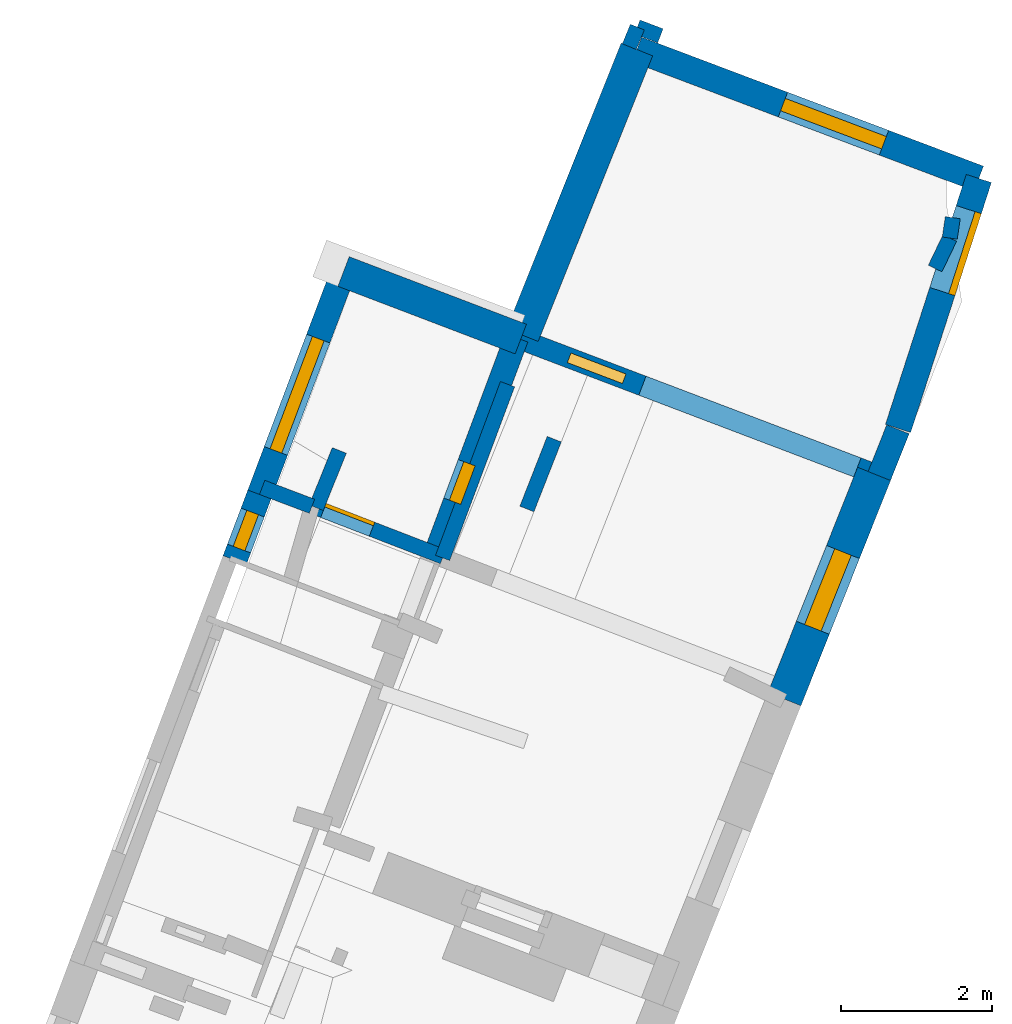
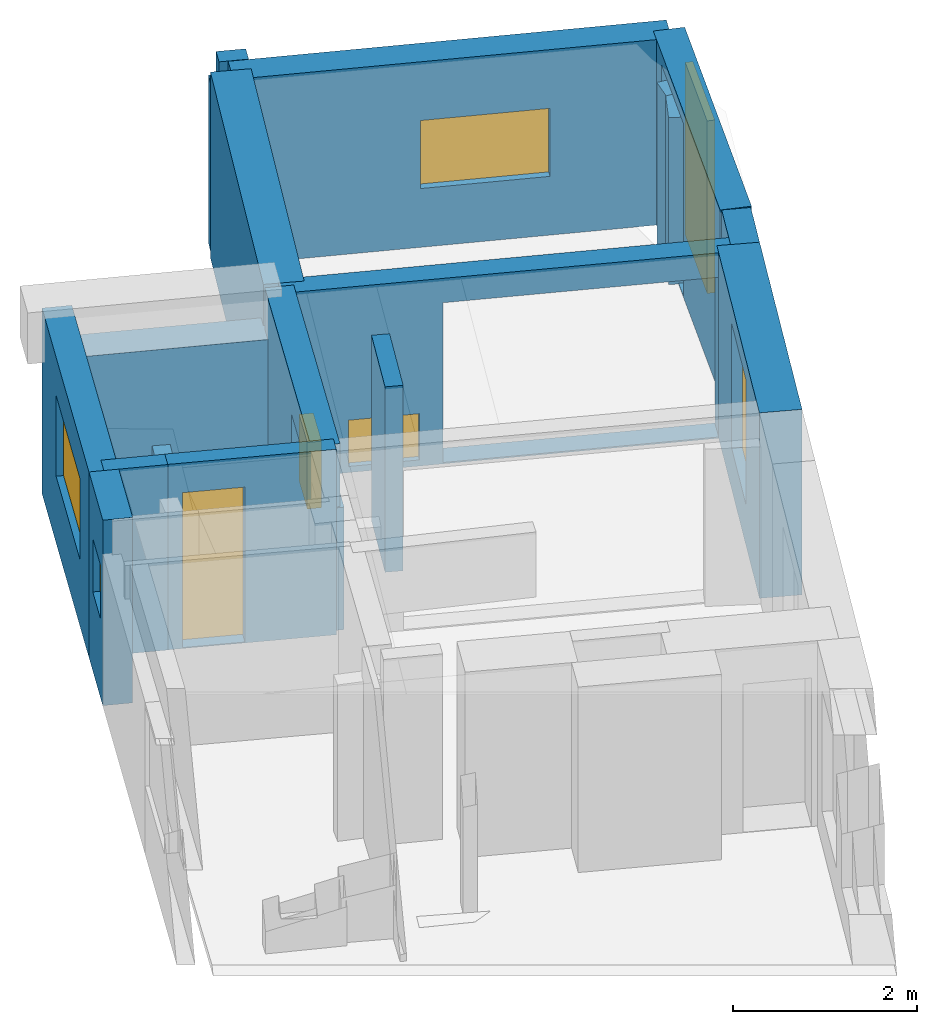
# One storey, part 3 of 5: 19 walls, 6 windows, 2 doors, 9 openings.
"""IFC2X3 building model written with IfcOpenShell, lengths in metres."""

from ifc_helpers import new_model, entity, si_unit, converted_unit, derived_unit, direction, frame, frame_2d, origin, origin_2d_with_axis, place, context, subcontext, project, spatial, polyline, rectangle, outline, extrude, source, transform, mapped, material, layer, layer_set, layer_usage, type_object, type_shapes, element, fill, save


model = new_model("IFC2X3")

# Units and contexts
model_context = context("Model", 3, precision=1e-05, world=origin(), true_north=direction((0.0, 1.0)))
body_context = subcontext(model_context, "Body", "Model", "MODEL_VIEW")
ifc_project = project(units=[si_unit("LENGTHUNIT", "METRE"), si_unit("AREAUNIT", "SQUARE_METRE"), si_unit("VOLUMEUNIT", "CUBIC_METRE"), converted_unit("PLANEANGLEUNIT", "DEGREE", entity("IfcRatioMeasure", 0.0174532925199433), si_unit("PLANEANGLEUNIT", "RADIAN"), dimensions=[0, 0, 0, 0, 0, 0, 0]), si_unit("MASSUNIT", "GRAM", prefix="KILO"), derived_unit("MASSDENSITYUNIT", [(si_unit("MASSUNIT", "GRAM", prefix="KILO"), 1), (si_unit("LENGTHUNIT", "METRE"), -3)]), derived_unit("MOMENTOFINERTIAUNIT", [(si_unit("LENGTHUNIT", "METRE"), 4)]), si_unit("TIMEUNIT", "SECOND"), si_unit("FREQUENCYUNIT", "HERTZ"), si_unit("THERMODYNAMICTEMPERATUREUNIT", "DEGREE_CELSIUS"), derived_unit("THERMALTRANSMITTANCEUNIT", [(si_unit("MASSUNIT", "GRAM", prefix="KILO"), 1), (si_unit("THERMODYNAMICTEMPERATUREUNIT", "KELVIN"), -1), (si_unit("TIMEUNIT", "SECOND"), -3)]), derived_unit("VOLUMETRICFLOWRATEUNIT", [(si_unit("LENGTHUNIT", "METRE"), 3), (si_unit("TIMEUNIT", "SECOND"), -1)]), si_unit("ELECTRICCURRENTUNIT", "AMPERE"), si_unit("ELECTRICVOLTAGEUNIT", "VOLT"), si_unit("POWERUNIT", "WATT"), si_unit("FORCEUNIT", "NEWTON", prefix="KILO"), si_unit("ILLUMINANCEUNIT", "LUX"), si_unit("LUMINOUSFLUXUNIT", "LUMEN"), si_unit("LUMINOUSINTENSITYUNIT", "CANDELA"), derived_unit("USERDEFINED", [(si_unit("MASSUNIT", "GRAM", prefix="KILO"), -1), (si_unit("LENGTHUNIT", "METRE"), -2), (si_unit("TIMEUNIT", "SECOND"), 3), (si_unit("LUMINOUSFLUXUNIT", "LUMEN"), 1)]), derived_unit("LINEARVELOCITYUNIT", [(si_unit("LENGTHUNIT", "METRE"), 1), (si_unit("TIMEUNIT", "SECOND"), -1)]), si_unit("PRESSUREUNIT", "PASCAL"), derived_unit("USERDEFINED", [(si_unit("LENGTHUNIT", "METRE"), -2), (si_unit("MASSUNIT", "GRAM", prefix="KILO"), 1), (si_unit("TIMEUNIT", "SECOND"), -2)]), derived_unit("LINEARFORCEUNIT", [(si_unit("MASSUNIT", "GRAM", prefix="KILO"), 1), (si_unit("LENGTHUNIT", "METRE"), 1), (si_unit("TIMEUNIT", "SECOND"), -2), (si_unit("LENGTHUNIT", "METRE"), -1)]), derived_unit("PLANARFORCEUNIT", [(si_unit("MASSUNIT", "GRAM", prefix="KILO"), 1), (si_unit("LENGTHUNIT", "METRE"), 1), (si_unit("TIMEUNIT", "SECOND"), -2), (si_unit("LENGTHUNIT", "METRE"), -2)])], contexts=[model_context])

# Site, building, storey
placement_1 = place(None, origin())
site = spatial("IfcSite", under=ifc_project, at=placement_1, CompositionType="ELEMENT")
building = spatial("IfcBuilding", under=site, at=placement_1, CompositionType="ELEMENT")
storey_placement = place(placement_1, frame((0.0, 0.0, -81.7791442871094)))
storey = spatial("IfcBuildingStorey", under=building, at=storey_placement, Name="Level 1", CompositionType="ELEMENT", Elevation=-81.7791442871094)

# Walls
ifc_material_1 = material(Name="Default wall")
ifc_layer_1 = layer(ifc_material_1, 0.2)
ifc_layer_set_1 = layer_set([ifc_layer_1], Name="wall_thickness_0.2000")
ifc_layer_usage_1 = layer_usage(ifc_layer_set_1, "AXIS2", "POSITIVE", -0.1)
wall_type_1 = type_object("IfcWallType", Name="wall_thickness_0.2000", PredefinedType="STANDARD", material=ifc_layer_set_1)
wall_1_placement = place(storey_placement, frame((0.534913213173563, 14.0127489770856, 0.0), z_axis=(0.0, 0.0, 1.0), x_axis=(-0.379483090969184, -0.925198672539295, 0.0)))
element("IfcWallStandardCase", 1, at=wall_1_placement, inside=storey, type_object=wall_type_1, material=ifc_layer_usage_1, Name="Wall:28", ObjectType="Wall", context=body_context, shape_type="SweptSolid", body=[
    extrude(outline(polyline([(0.280202532892846, -0.1), (0.280202532892846, 0.1), (0.0, 0.1), (0.0, -0.1), (0.280202532892846, -0.1)])), origin(), (0.0, 0.0, 1.0), 2.23354339599609),
])
wall_2_placement = place(storey_placement, frame((-1.18385248926495, 9.2848220301749, 0.0), z_axis=(0.0, 0.0, 1.0), x_axis=(-0.350013235977409, -0.936744754263734, 0.0)))
element("IfcWallStandardCase", 2, at=wall_2_placement, inside=storey, type_object=wall_type_1, material=ifc_layer_usage_1, Name="Wall:30", ObjectType="Wall", context=body_context, shape_type="SweptSolid", body=[
    extrude(outline(polyline([(2.45518731970475, -0.1), (2.45518731970475, 0.1), (0.0, 0.1), (0.0, -0.1), (2.45518731970475, -0.1)])), origin(), (0.0, 0.0, 1.0), 1.62880706787109),
])
wall_3_placement = place(storey_placement, frame((-0.565016196030518, 8.55692528998831, 0.0), z_axis=(0.0, 0.0, 1.0), x_axis=(-0.365185671787063, -0.930934705079487, 0.0)))
element("IfcWallStandardCase", 3, at=wall_3_placement, inside=storey, type_object=wall_type_1, material=ifc_layer_usage_1, Name="Wall:49", ObjectType="Wall", context=body_context, shape_type="SweptSolid", body=[
    extrude(outline(polyline([(0.992160278720663, -0.1), (0.992160278720663, 0.1), (0.0, 0.1), (0.0, -0.1), (0.992160278720663, -0.1)])), origin(), (0.0, 0.0, 1.0), 2.46645965576172),
])
wall_4_placement = place(storey_placement, frame((-3.41037913404314, 8.40823391612898, 0.0), z_axis=(0.0, 0.0, 1.0), x_axis=(-0.373585462771067, -0.927595764331709, 0.0)))
element("IfcWallStandardCase", 4, at=wall_4_placement, inside=storey, type_object=wall_type_1, material=ifc_layer_usage_1, Name="Wall:53", ObjectType="Wall", context=body_context, shape_type="SweptSolid", body=[
    extrude(outline(polyline([(0.817462287306369, -0.1), (0.817462287306369, 0.1), (0.0, 0.1), (0.0, -0.1), (0.817462287306369, -0.1)])), origin(), (0.0, 0.0, 1.0), 2.08080291748047),
])
wall_5_placement = place(storey_placement, frame((0.840400958394622, 13.8964334556276, 0.0), z_axis=(0.0, 0.0, 1.0), x_axis=(-0.934550229836624, 0.355831235155535, 0.0)))
element("IfcWallStandardCase", 5, at=wall_5_placement, inside=storey, type_object=wall_type_1, material=ifc_layer_usage_1, Name="Wall:54", ObjectType="Wall", context=body_context, shape_type="SweptSolid", body=[
    extrude(outline(polyline([(0.326882174774922, -0.1), (0.326882174774922, 0.1), (0.0, 0.1), (0.0, -0.1), (0.326882174774922, -0.1)])), origin(), (0.0, 0.0, 1.0), 2.46645965576172),
])
wall_6_placement = place(storey_placement, frame((4.67075637080237, 11.2193282866582, 0.0), z_axis=(0.0, 0.0, 1.0), x_axis=(-0.432838851442395, -0.901471313288464, 0.0)))
element("IfcWallStandardCase", 6, at=wall_6_placement, inside=storey, type_object=wall_type_1, material=ifc_layer_usage_1, Name="Wall:77", ObjectType="Wall", context=body_context, shape_type="SweptSolid", body=[
    extrude(outline(polyline([(0.447134619766838, -0.1), (0.447134619766838, 0.1), (0.0, 0.1), (0.0, -0.1), (0.447134619766838, -0.1)])), origin(), (0.0, 0.0, 1.0), 2.21805572509766),
])
wall_7_placement = place(storey_placement, frame((-4.43193251056362, 7.91902260949432, 0.0), z_axis=(0.0, 0.0, 1.0), x_axis=(0.93509236593609, -0.354404101511319, 0.0)))
element("IfcWallStandardCase", 7, at=wall_7_placement, inside=storey, type_object=wall_type_1, material=ifc_layer_usage_1, Name="Wall:83", ObjectType="Wall", context=body_context, shape_type="SweptSolid", body=[
    extrude(outline(polyline([(0.705679881249374, -0.1), (0.705679881249374, 0.1), (0.0, 0.1), (0.0, -0.1), (0.705679881249374, -0.1)])), origin(), (0.0, 0.0, 1.0), 2.46645965576172),
])
wall_8_placement = place(storey_placement, frame((4.71052920471825, 11.4896001543903, 0.0), z_axis=(0.0, 0.0, 1.0), x_axis=(-0.145589265881267, -0.98934511959182, 0.0)))
element("IfcWallStandardCase", 8, at=wall_8_placement, inside=storey, type_object=wall_type_1, material=ifc_layer_usage_1, Name="Wall:87", ObjectType="Wall", context=body_context, shape_type="SweptSolid", body=[
    extrude(outline(polyline([(0.273182986999881, -0.1), (0.273182986999881, 0.1), (0.0, 0.1), (0.0, -0.1), (0.273182986999881, -0.1)])), origin(), (0.0, 0.0, 1.0), 2.21805572509766),
])

# Wall, opening, window
ifc_layer_2 = layer(ifc_material_1, 0.330000013113022)
ifc_layer_set_2 = layer_set([ifc_layer_2], Name="wall_thickness_0.3300")
ifc_layer_usage_2 = layer_usage(ifc_layer_set_2, "AXIS2", "POSITIVE", -0.165000006556511)
wall_type_2 = type_object("IfcWallType", Name="wall_thickness_0.3300", PredefinedType="STANDARD", material=ifc_layer_set_2)
wall_9_placement = place(storey_placement, frame((-3.35402105928155, 10.7769497737443, 0.0), z_axis=(0.0, 0.0, 1.0), x_axis=(-0.352899233573497, -0.935661333465928, 0.0)))
wall_9 = element("IfcWallStandardCase", 9, at=wall_9_placement, inside=storey, type_object=wall_type_2, material=ifc_layer_usage_2, Name="Wall:5", ObjectType="Wall", context=body_context, shape_type="SweptSolid", body=[
    extrude(outline(polyline([(3.15444612027682, -0.165000006556511), (3.15444612027682, 0.165000006556511), (0.0, 0.165000006556511), (0.0, -0.165000006556511), (3.15444612027682, -0.165000006556511)])), origin(), (0.0, 0.0, 1.0), 2.46645965576172),
])
opening_1_placement = place(wall_9_placement, frame((0.94920766898592, -0.165000006556511, 0.885063171386719)))
opening_1 = element("IfcOpeningElement", 10, at=opening_1_placement, cuts=wall_9, Name="Opening : 1590 x 1075 : 0", ObjectType="Opening", context=body_context, shape_type="SweptSolid", body=[
    extrude(rectangle(XDim=1.59, YDim=1.075, at=frame_2d((0.5375, 0.795), x_axis=(0.0, 1.0))), frame((0.0, 0.0, 0.0), z_axis=(0.0, 1.0, 0.0), x_axis=(0.0, 0.0, 1.0)), (0.0, 0.0, 1.0), 0.330000013113022),
])
ifc_material_2 = material(Name="Window Default")
window_style_1 = type_object("IfcWindowStyle", Name="Window : 1590 x 1075mm", ConstructionType="NOTDEFINED", OperationType="NOTDEFINED", ParameterTakesPrecedence=False, Sizeable=False, material=ifc_material_2)
shared_shape_1 = source(origin(), body_context, "Body", "SweptSolid", [
    extrude(rectangle(XDim=0.165000006556511, YDim=1.59, at=origin_2d_with_axis()), frame((0.795, 0.165000006556511, 0.0), z_axis=(0.0, 0.0, 1.0), x_axis=(0.0, 1.0, 0.0)), (0.0, 0.0, 1.0), 1.075),
])
type_shapes(window_style_1, [shared_shape_1])
window_1_placement = place(opening_1_placement, origin())
window_1 = element("IfcWindow", 11, at=window_1_placement, inside=storey, type_object=window_style_1, Name="Window : 1590 x 1075mm : 0", ObjectType="Window : 1590 x 1075mm", OverallHeight=1.075, OverallWidth=1.59, context=body_context, shape_type="MappedRepresentation", body=[
    mapped(shared_shape_1, transform((0.0, 0.0, 0.0), scale=1.0)),
])
fill(opening_1, window_1)

wall_10_placement = place(storey_placement, frame((-4.46722267747613, 7.82545651049972, 0.0), z_axis=(0.0, 0.0, 1.0), x_axis=(-0.352899133389715, -0.935661371251794, 0.0)))
wall_10 = element("IfcWallStandardCase", 12, at=wall_10_placement, inside=storey, type_object=wall_type_2, material=ifc_layer_usage_2, Name="Wall:6", ObjectType="Wall", context=body_context, shape_type="SweptSolid", body=[
    extrude(outline(polyline([(0.929730699507726, -0.165000006556511), (0.929730699507726, 0.165000006556511), (0.0, 0.165000006556511), (0.0, -0.165000006556511), (0.929730699507726, -0.165000006556511)])), origin(), (0.0, 0.0, 1.0), 2.46645965576172),
])
opening_2_placement = place(wall_10_placement, frame((0.255672210249831, -0.165000006556511, 1.04679870605469)))
opening_2 = element("IfcOpeningElement", 13, at=opening_2_placement, cuts=wall_10, Name="Opening : 510 x 715 : 1", ObjectType="Opening", context=body_context, shape_type="SweptSolid", body=[
    extrude(rectangle(XDim=0.51, YDim=0.715, at=frame_2d((0.3575, 0.255), x_axis=(0.0, 1.0))), frame((0.0, 0.0, 0.0), z_axis=(0.0, 1.0, 0.0), x_axis=(0.0, 0.0, 1.0)), (0.0, 0.0, 1.0), 0.330000013113022),
])
window_style_2 = type_object("IfcWindowStyle", Name="Window : 510 x 715mm", ConstructionType="NOTDEFINED", OperationType="NOTDEFINED", ParameterTakesPrecedence=False, Sizeable=False, material=ifc_material_2)
shared_shape_2 = source(origin(), body_context, "Body", "SweptSolid", [
    extrude(rectangle(XDim=0.165000006556511, YDim=0.51, at=origin_2d_with_axis()), frame((0.255, 0.165000006556511, 0.0), z_axis=(0.0, 0.0, 1.0), x_axis=(0.0, 1.0, 0.0)), (0.0, 0.0, 1.0), 0.715),
])
type_shapes(window_style_2, [shared_shape_2])
window_2_placement = place(opening_2_placement, origin())
window_2 = element("IfcWindow", 14, at=window_2_placement, inside=storey, type_object=window_style_2, Name="Window : 510 x 715mm : 1", ObjectType="Window : 510 x 715mm", OverallHeight=0.715, OverallWidth=0.51, context=body_context, shape_type="MappedRepresentation", body=[
    mapped(shared_shape_2, transform((0.0, 0.0, 0.0), scale=1.0)),
])
fill(opening_2, window_2)

# Wall
ifc_layer_3 = layer(ifc_material_1, 0.449999988079071)
ifc_layer_set_3 = layer_set([ifc_layer_3], Name="wall_thickness_0.4500")
ifc_layer_usage_3 = layer_usage(ifc_layer_set_3, "AXIS2", "POSITIVE", -0.224999994039536)
wall_type_3 = type_object("IfcWallType", Name="wall_thickness_0.4500", PredefinedType="STANDARD", material=ifc_layer_set_3)
wall_11_placement = place(storey_placement, frame((0.529516808402204, 13.7154265775871, 0.0), z_axis=(0.0, 0.0, 1.0), x_axis=(-0.372255670054105, -0.928130225837177, 0.0)))
element("IfcWallStandardCase", 15, at=wall_11_placement, inside=storey, type_object=wall_type_3, material=ifc_layer_usage_3, Name="Wall:88", ObjectType="Wall", context=body_context, shape_type="SweptSolid", body=[
    extrude(outline(polyline([(4.07386618102271, -0.224999994039536), (4.07386618102271, 0.224999994039536), (0.0, 0.224999994039536), (0.0, -0.224999994039536), (4.07386618102271, -0.224999994039536)])), origin(), (0.0, 0.0, 1.0), 2.46645965576172),
])

# Wall, opening, window
ifc_layer_4 = layer(ifc_material_1, 0.469999998807907)
ifc_layer_set_4 = layer_set([ifc_layer_4], Name="wall_thickness_0.4700")
ifc_layer_usage_4 = layer_usage(ifc_layer_set_4, "AXIS2", "POSITIVE", -0.234999999403954)
wall_type_4 = type_object("IfcWallType", Name="wall_thickness_0.4700", PredefinedType="STANDARD", material=ifc_layer_set_4)
wall_12_placement = place(storey_placement, frame((3.66932552365206, 8.09889642050293, 0.0), z_axis=(0.0, 0.0, 1.0), x_axis=(-0.369820296727494, -0.929103303259863, 0.0)))
wall_12 = element("IfcWallStandardCase", 16, at=wall_12_placement, inside=storey, type_object=wall_type_4, material=ifc_layer_usage_4, Name="Wall:21", ObjectType="Wall", context=body_context, shape_type="SweptSolid", body=[
    extrude(outline(polyline([(3.21089586634122, -0.234999999403954), (3.21089586634122, 0.234999999403954), (0.0, 0.234999999403954), (0.0, -0.234999999403954), (3.21089586634122, -0.234999999403954)])), origin(), (0.0, 0.0, 1.0), 2.46645965576172),
])
opening_3_placement = place(wall_12_placement, frame((1.11393960544685, -0.234999999403954, 0.545059204101562)))
opening_3 = element("IfcOpeningElement", 17, at=opening_3_placement, cuts=wall_12, Name="Opening : 1080 x 1660 : 5", ObjectType="Opening", context=body_context, shape_type="SweptSolid", body=[
    extrude(rectangle(XDim=1.08, YDim=1.66, at=frame_2d((0.83, 0.54), x_axis=(0.0, 1.0))), frame((0.0, 0.0, 0.0), z_axis=(0.0, 1.0, 0.0), x_axis=(0.0, 0.0, 1.0)), (0.0, 0.0, 1.0), 0.469999998807907),
])
window_style_3 = type_object("IfcWindowStyle", Name="Window : 1080 x 1660mm", ConstructionType="NOTDEFINED", OperationType="NOTDEFINED", ParameterTakesPrecedence=False, Sizeable=False, material=ifc_material_2)
shared_shape_3 = source(origin(), body_context, "Body", "SweptSolid", [
    extrude(rectangle(XDim=0.234999999403954, YDim=1.08, at=origin_2d_with_axis()), frame((0.54, 0.234999999403954, 0.0), z_axis=(0.0, 0.0, 1.0), x_axis=(0.0, 1.0, 0.0)), (0.0, 0.0, 1.0), 1.66),
])
type_shapes(window_style_3, [shared_shape_3])
window_3_placement = place(opening_3_placement, origin())
window_3 = element("IfcWindow", 18, at=window_3_placement, inside=storey, type_object=window_style_3, Name="Window : 1080 x 1660mm : 4", ObjectType="Window : 1080 x 1660mm", OverallHeight=1.66, OverallWidth=1.08, context=body_context, shape_type="MappedRepresentation", body=[
    mapped(shared_shape_3, transform((0.0, 0.0, 0.0), scale=1.0)),
])
fill(opening_3, window_3)

# Wall, opening, door
ifc_layer_5 = layer(ifc_material_1, 0.200000002980232)
ifc_layer_set_5 = layer_set([ifc_layer_5], Name="wall_thickness_0.2000")
ifc_layer_usage_5 = layer_usage(ifc_layer_set_5, "AXIS2", "POSITIVE", -0.100000001490116)
wall_type_5 = type_object("IfcWallType", Name="wall_thickness_0.2000", PredefinedType="STANDARD", material=ifc_layer_set_5)
wall_13_placement = place(storey_placement, frame((-3.77134199785102, 7.67141800402129, 0.0), z_axis=(0.0, 0.0, 1.0), x_axis=(0.932862377574949, -0.360232958660382, 0.0)))
wall_13 = element("IfcWallStandardCase", 19, at=wall_13_placement, inside=storey, type_object=wall_type_5, material=ifc_layer_usage_5, Name="Wall:62", ObjectType="Wall", context=body_context, shape_type="SweptSolid", body=[
    extrude(outline(polyline([(1.85921547253989, -0.100000001490116), (1.85921547253989, 0.100000001490116), (0.0, 0.100000001490116), (0.0, -0.100000001490116), (1.85921547253989, -0.100000001490116)])), origin(), (0.0, 0.0, 1.0), 2.46645965576172),
])
opening_4_placement = place(wall_13_placement, frame((0.161015165395214, -0.100000001490116, 0.0127944946289062)))
opening_4 = element("IfcOpeningElement", 20, at=opening_4_placement, cuts=wall_13, Name="Opening : 690 x 2060 : 17", ObjectType="Opening", context=body_context, shape_type="SweptSolid", body=[
    extrude(rectangle(XDim=0.69, YDim=2.06, at=frame_2d((1.03, 0.345), x_axis=(0.0, 1.0))), frame((0.0, 0.0, 0.0), z_axis=(0.0, 1.0, 0.0), x_axis=(0.0, 0.0, 1.0)), (0.0, 0.0, 1.0), 0.200000002980232),
])
ifc_material_3 = material(Name="Door Panel")
door_style_1 = type_object("IfcDoorStyle", Name="Door : 690 x 2060mm", ConstructionType="NOTDEFINED", OperationType="SINGLE_SWING_RIGHT", ParameterTakesPrecedence=False, Sizeable=False, material=ifc_material_3)
shared_shape_4 = source(origin(), body_context, "Body", "SweptSolid", [
    extrude(rectangle(XDim=0.0500000007450581, YDim=0.69, at=origin_2d_with_axis()), frame((0.345, 0.175000002607703, 0.0), z_axis=(0.0, 0.0, 1.0), x_axis=(0.0, 1.0, 0.0)), (0.0, 0.0, 1.0), 2.06),
])
type_shapes(door_style_1, [shared_shape_4])
door_1_placement = place(opening_4_placement, origin())
door_1 = element("IfcDoor", 21, at=door_1_placement, inside=storey, type_object=door_style_1, Name="Door : 690 x 2060mm : 3", ObjectType="Door : 690 x 2060mm", OverallHeight=2.06, OverallWidth=0.69, context=body_context, shape_type="MappedRepresentation", body=[
    mapped(shared_shape_4, transform((0.0, 0.0, 0.0), scale=1.0)),
])
fill(opening_4, door_1)

# Wall
ifc_layer_6 = layer(ifc_material_1, 0.319999992847443)
ifc_layer_set_6 = layer_set([ifc_layer_6], Name="wall_thickness_0.3200")
ifc_layer_usage_6 = layer_usage(ifc_layer_set_6, "AXIS2", "POSITIVE", -0.159999996423721)
wall_type_6 = type_object("IfcWallType", Name="wall_thickness_0.3200", PredefinedType="STANDARD", material=ifc_layer_set_6)
wall_14_placement = place(storey_placement, frame((3.98431233915128, 8.68744034564524, 0.0), z_axis=(0.0, 0.0, 1.0), x_axis=(-0.369819075711334, -0.929103789272229, 0.0)))
element("IfcWallStandardCase", 22, at=wall_14_placement, inside=storey, type_object=wall_type_6, material=ifc_layer_usage_6, Name="Wall:19", ObjectType="Wall", context=body_context, shape_type="SweptSolid", body=[
    extrude(outline(polyline([(0.664977524196902, -0.159999996423721), (0.664977524196902, 0.159999996423721), (0.0, 0.159999996423721), (0.0, -0.159999996423721), (0.664977524196902, -0.159999996423721)])), origin(), (0.0, 0.0, 1.0), 2.46645965576172),
])

# Wall, opening, window
placement_2 = place(placement_1, frame((0.0, 0.0, -81.3283386230469)))
wall_15_placement = place(placement_2, frame((-1.06425241874934, 9.89881890867105, 0.0), z_axis=(0.0, 0.0, 1.0), x_axis=(-0.350153169987652, -0.936692456224346, 0.0)))
wall_15 = element("IfcWallStandardCase", 23, at=wall_15_placement, inside=storey, type_object=wall_type_6, material=ifc_layer_usage_6, Name="Wall:33", ObjectType="Wall", context=body_context, shape_type="SweptSolid", body=[
    extrude(outline(polyline([(3.05321998922829, -0.159999996423721), (3.05321998922829, 0.159999996423721), (0.0, 0.159999996423721), (0.0, -0.159999996423721), (3.05321998922829, -0.159999996423721)])), origin(), (0.0, 0.0, 1.0), 2.01565399169922),
])
opening_5_placement = place(wall_15_placement, frame((1.77930361533483, -0.159999996423721, 0.668739318847656)))
opening_5 = element("IfcOpeningElement", 24, at=opening_5_placement, cuts=wall_15, Name="Opening : 545 x 885 : 10", ObjectType="Opening", context=body_context, shape_type="SweptSolid", body=[
    extrude(rectangle(XDim=0.545, YDim=0.885, at=frame_2d((0.4425, 0.2725), x_axis=(0.0, 1.0))), frame((0.0, 0.0, 0.0), z_axis=(0.0, 1.0, 0.0), x_axis=(0.0, 0.0, 1.0)), (0.0, 0.0, 1.0), 0.319999992847443),
])
window_style_4 = type_object("IfcWindowStyle", Name="Window : 545 x 885mm", ConstructionType="NOTDEFINED", OperationType="NOTDEFINED", ParameterTakesPrecedence=False, Sizeable=False, material=ifc_material_2)
shared_shape_5 = source(origin(), body_context, "Body", "SweptSolid", [
    extrude(rectangle(XDim=0.159999996423721, YDim=0.545, at=origin_2d_with_axis()), frame((0.2725, 0.159999996423721, 0.0), z_axis=(0.0, 0.0, 1.0), x_axis=(0.0, 1.0, 0.0)), (0.0, 0.0, 1.0), 0.885),
])
type_shapes(window_style_4, [shared_shape_5])
window_4_placement = place(opening_5_placement, origin())
window_4 = element("IfcWindow", 25, at=window_4_placement, inside=storey, type_object=window_style_4, Name="Window : 545 x 885mm : 8", ObjectType="Window : 545 x 885mm", OverallHeight=0.885, OverallWidth=0.545, context=body_context, shape_type="MappedRepresentation", body=[
    mapped(shared_shape_5, transform((0.0, 0.0, 0.0), scale=1.0)),
])
fill(opening_5, window_4)

# Wall
ifc_layer_7 = layer(ifc_material_1, 0.419999986886978)
ifc_layer_set_7 = layer_set([ifc_layer_7], Name="wall_thickness_0.4200")
ifc_layer_usage_7 = layer_usage(ifc_layer_set_7, "AXIS2", "POSITIVE", -0.209999993443489)
wall_type_7 = type_object("IfcWallType", Name="wall_thickness_0.4200", PredefinedType="STANDARD", material=ifc_layer_set_7)
wall_16_placement = place(storey_placement, frame((-3.3540222931076, 10.7769483583236, 0.0), z_axis=(0.0, 0.0, 1.0), x_axis=(0.934394750063348, -0.356239317108672, 0.0)))
element("IfcWallStandardCase", 26, at=wall_16_placement, inside=storey, type_object=wall_type_7, material=ifc_layer_usage_7, Name="Wall:38", ObjectType="Wall", context=body_context, shape_type="SweptSolid", body=[
    extrude(outline(polyline([(2.51093580563089, -0.209999993443489), (2.51093580563089, 0.209999993443489), (0.0, 0.209999993443489), (0.0, -0.209999993443489), (2.51093580563089, -0.209999993443489)])), origin(), (0.0, 0.0, 1.0), 1.91806030273438),
])

# Wall, openings, window
ifc_layer_8 = layer(ifc_material_1, 0.270000010728836)
ifc_layer_set_8 = layer_set([ifc_layer_8], Name="wall_thickness_0.2700")
ifc_layer_usage_8 = layer_usage(ifc_layer_set_8, "AXIS2", "POSITIVE", -0.135000005364418)
wall_type_8 = type_object("IfcWallType", Name="wall_thickness_0.2700", PredefinedType="STANDARD", material=ifc_layer_set_8)
wall_17_placement = place(storey_placement, frame((-1.0642528810664, 9.8988190497436, 0.0), z_axis=(0.0, 0.0, 1.0), x_axis=(0.934707221285478, -0.355418641149814, 0.0)))
wall_17 = element("IfcWallStandardCase", 27, at=wall_17_placement, inside=storey, type_object=wall_type_8, material=ifc_layer_usage_8, Name="Wall:68", ObjectType="Wall", context=body_context, shape_type="SweptSolid", body=[
    extrude(outline(polyline([(5.13924609130098, -0.135000005364418), (5.13924609130098, 0.135000005364418), (0.0, 0.135000005364418), (0.0, -0.135000005364418), (5.13924609130098, -0.135000005364418)])), origin(), (0.0, 0.0, 1.0), 2.46645965576172),
])
opening_6_placement = place(wall_17_placement, frame((1.78250003389209, -0.135000005364418, 0.0177993774414062)))
element("IfcOpeningElement", 28, at=opening_6_placement, cuts=wall_17, Name="Opening : 3045 x 2125 : 18", ObjectType="Opening", context=body_context, shape_type="SweptSolid", body=[
    extrude(rectangle(XDim=3.045, YDim=2.125, at=frame_2d((1.0625, 1.5225), x_axis=(0.0, 1.0))), frame((0.0, 0.0, 0.0), z_axis=(0.0, 1.0, 0.0), x_axis=(0.0, 0.0, 1.0)), (0.0, 0.0, 1.0), 0.270000010728836),
])
opening_7_placement = place(wall_17_placement, frame((0.744784798081429, -0.135000005364418, 0.0818023681640625)))
opening_7 = element("IfcOpeningElement", 29, at=opening_7_placement, cuts=wall_17, Name="Opening : 780 x 615 : 19", ObjectType="Opening", context=body_context, shape_type="SweptSolid", body=[
    extrude(rectangle(XDim=0.78, YDim=0.615, at=frame_2d((0.3075, 0.39), x_axis=(0.0, 1.0))), frame((0.0, 0.0, 0.0), z_axis=(0.0, 1.0, 0.0), x_axis=(0.0, 0.0, 1.0)), (0.0, 0.0, 1.0), 0.270000010728836),
])
window_style_5 = type_object("IfcWindowStyle", Name="Window : 780 x 615mm", ConstructionType="NOTDEFINED", OperationType="NOTDEFINED", ParameterTakesPrecedence=False, Sizeable=False, material=ifc_material_2)
shared_shape_6 = source(origin(), body_context, "Body", "SweptSolid", [
    extrude(rectangle(XDim=0.135000005364418, YDim=0.78, at=origin_2d_with_axis()), frame((0.39, 0.135000005364418, 0.0), z_axis=(0.0, 0.0, 1.0), x_axis=(0.0, 1.0, 0.0)), (0.0, 0.0, 1.0), 0.615),
])
type_shapes(window_style_5, [shared_shape_6])
window_5_placement = place(opening_7_placement, origin())
window_5 = element("IfcWindow", 30, at=window_5_placement, inside=storey, type_object=window_style_5, Name="Window : 780 x 615mm : 13", ObjectType="Window : 780 x 615mm", OverallHeight=0.615, OverallWidth=0.78, context=body_context, shape_type="MappedRepresentation", body=[
    mapped(shared_shape_6, transform((0.0, 0.0, 0.0), scale=1.0)),
])
fill(opening_7, window_5)

# Wall, opening, window
ifc_layer_9 = layer(ifc_material_1, 0.349999994039536)
ifc_layer_set_9 = layer_set([ifc_layer_9], Name="wall_thickness_0.3500")
ifc_layer_usage_9 = layer_usage(ifc_layer_set_9, "AXIS2", "POSITIVE", -0.174999997019768)
wall_type_9 = type_object("IfcWallType", Name="wall_thickness_0.3500", PredefinedType="STANDARD", material=ifc_layer_set_9)
wall_18_placement = place(storey_placement, frame((0.52951710182445, 13.7154264314961, 0.0), z_axis=(0.0, 0.0, 1.0), x_axis=(0.935630810783965, -0.352980149458492, 0.0)))
wall_18 = element("IfcWallStandardCase", 31, at=wall_18_placement, inside=storey, type_object=wall_type_9, material=ifc_layer_usage_9, Name="Wall:73", ObjectType="Wall", context=body_context, shape_type="SweptSolid", body=[
    extrude(outline(polyline([(4.83732436384357, -0.174999997019768), (4.83732436384357, 0.174999997019768), (0.0, 0.174999997019768), (0.0, -0.174999997019768), (4.83732436384357, -0.174999997019768)])), origin(), (0.0, 0.0, 1.0), 2.46645965576172),
])
opening_8_placement = place(wall_18_placement, frame((2.06559505378305, -0.174999997019768, 0.781051635742188)))
opening_8 = element("IfcOpeningElement", 32, at=opening_8_placement, cuts=wall_18, Name="Opening : 1430 x 905 : 21", ObjectType="Opening", context=body_context, shape_type="SweptSolid", body=[
    extrude(rectangle(XDim=1.43, YDim=0.905, at=frame_2d((0.4525, 0.715), x_axis=(0.0, 1.0))), frame((0.0, 0.0, 0.0), z_axis=(0.0, 1.0, 0.0), x_axis=(0.0, 0.0, 1.0)), (0.0, 0.0, 1.0), 0.349999994039536),
])
window_style_6 = type_object("IfcWindowStyle", Name="Window : 1430 x 905mm", ConstructionType="NOTDEFINED", OperationType="NOTDEFINED", ParameterTakesPrecedence=False, Sizeable=False, material=ifc_material_2)
shared_shape_7 = source(origin(), body_context, "Body", "SweptSolid", [
    extrude(rectangle(XDim=0.174999997019768, YDim=1.43, at=origin_2d_with_axis()), frame((0.715, 0.174999997019768, 0.0), z_axis=(0.0, 0.0, 1.0), x_axis=(0.0, 1.0, 0.0)), (0.0, 0.0, 1.0), 0.905),
])
type_shapes(window_style_6, [shared_shape_7])
window_6_placement = place(opening_8_placement, origin())
window_6 = element("IfcWindow", 33, at=window_6_placement, inside=storey, type_object=window_style_6, Name="Window : 1430 x 905mm : 14", ObjectType="Window : 1430 x 905mm", OverallHeight=0.905, OverallWidth=1.43, context=body_context, shape_type="MappedRepresentation", body=[
    mapped(shared_shape_7, transform((0.0, 0.0, 0.0), scale=1.0)),
])
fill(opening_8, window_6)

# Wall, opening, door
wall_19_placement = place(storey_placement, frame((5.05546735719822, 12.0079469283972, 0.0), z_axis=(0.0, 0.0, 1.0), x_axis=(-0.307459432465256, -0.951561189513393, 0.0)))
wall_19 = element("IfcWallStandardCase", 34, at=wall_19_placement, inside=storey, type_object=wall_type_9, material=ifc_layer_usage_9, Name="Wall:82", ObjectType="Wall", context=body_context, shape_type="SweptSolid", body=[
    extrude(outline(polyline([(3.47727385349899, -0.174999997019768), (3.47727385349899, 0.174999997019768), (0.0, 0.174999997019768), (0.0, -0.174999997019768), (3.47727385349899, -0.174999997019768)])), origin(), (0.0, 0.0, 1.0), 2.46645965576172),
])
opening_9_placement = place(wall_19_placement, frame((0.432615611584013, -0.174999997019768, 0.0130538940429688)))
opening_9 = element("IfcOpeningElement", 35, at=opening_9_placement, cuts=wall_19, Name="Opening : 1140 x 2295 : 23", ObjectType="Opening", context=body_context, shape_type="SweptSolid", body=[
    extrude(rectangle(XDim=1.14, YDim=2.295, at=frame_2d((1.1475, 0.57), x_axis=(0.0, 1.0))), frame((0.0, 0.0, 0.0), z_axis=(0.0, 1.0, 0.0), x_axis=(0.0, 0.0, 1.0)), (0.0, 0.0, 1.0), 0.349999994039536),
])
door_style_2 = type_object("IfcDoorStyle", Name="Door : 1140 x 2295mm", ConstructionType="NOTDEFINED", OperationType="SINGLE_SWING_RIGHT", ParameterTakesPrecedence=False, Sizeable=False, material=ifc_material_3)
shared_shape_8 = source(origin(), body_context, "Body", "SweptSolid", [
    extrude(rectangle(XDim=0.0874999985098839, YDim=1.14, at=origin_2d_with_axis()), frame((0.57, 0.306249994784594, 0.0), z_axis=(0.0, 0.0, 1.0), x_axis=(0.0, 1.0, 0.0)), (0.0, 0.0, 1.0), 2.295),
])
type_shapes(door_style_2, [shared_shape_8])
door_2_placement = place(opening_9_placement, origin())
door_2 = element("IfcDoor", 36, at=door_2_placement, inside=storey, type_object=door_style_2, Name="Door : 1140 x 2295mm : 6", ObjectType="Door : 1140 x 2295mm", OverallHeight=2.295, OverallWidth=1.14, context=body_context, shape_type="MappedRepresentation", body=[
    mapped(shared_shape_8, transform((0.0, 0.0, 0.0), scale=1.0)),
])
fill(opening_9, door_2)

save(model, "model.ifc")
